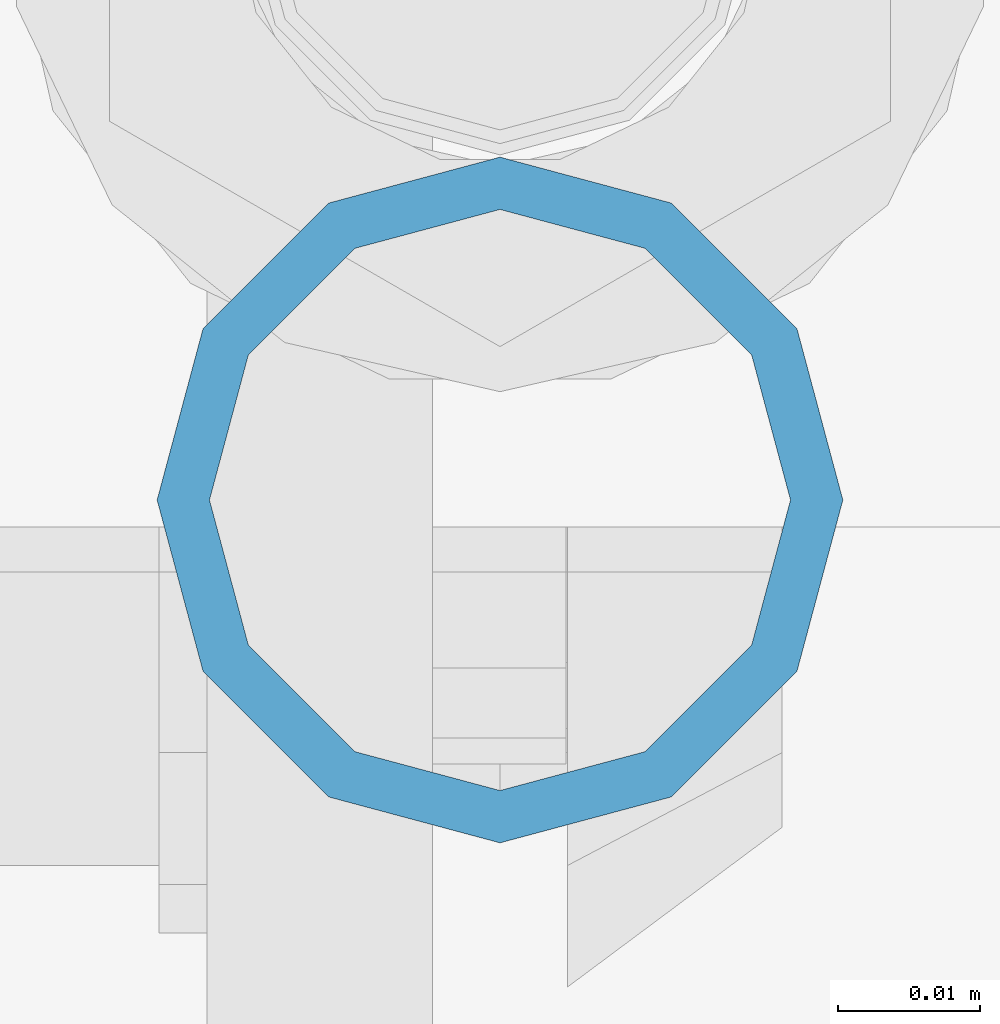
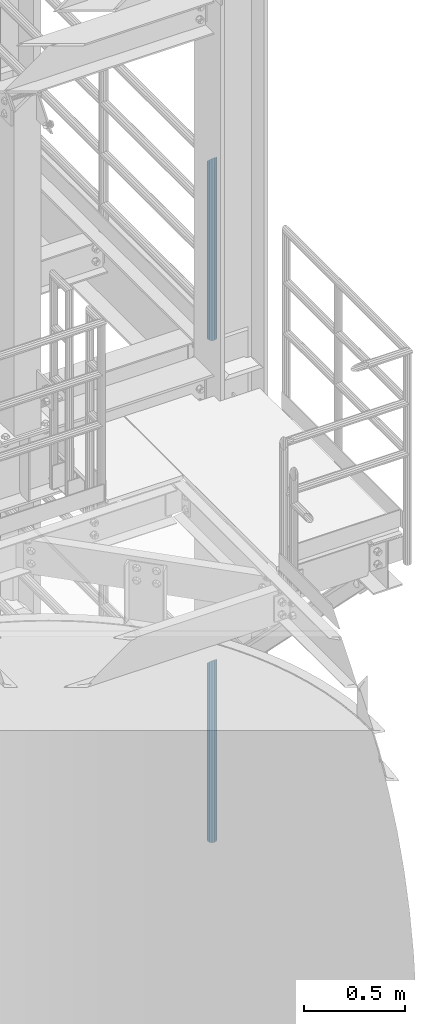
# One storey, part 657 of 1876: 2 columns, 2 elements without a shape of their own.
"""IFC2X3 building model written with IfcOpenShell, lengths in millimetres."""

from ifc_helpers import new_model, si_unit, frame, origin_with_axes, place, context, subcontext, project, spatial, faceted_brep, material, type_object, element, aggregate, save


model = new_model("IFC2X3")

# Units and contexts
model_context = context("Model", 3, precision=1e-05, world=origin_with_axes())
body_context = subcontext(model_context, "Body", "Model", "MODEL_VIEW")
ifc_project = project(units=[si_unit("LENGTHUNIT", "METRE", prefix="MILLI"), si_unit("AREAUNIT", "SQUARE_METRE"), si_unit("VOLUMEUNIT", "CUBIC_METRE"), si_unit("MASSUNIT", "GRAM", prefix="KILO"), si_unit("TIMEUNIT", "SECOND"), si_unit("PLANEANGLEUNIT", "RADIAN"), si_unit("SOLIDANGLEUNIT", "STERADIAN"), si_unit("THERMODYNAMICTEMPERATUREUNIT", "DEGREE_CELSIUS"), si_unit("LUMINOUSINTENSITYUNIT", "LUMEN")], contexts=[model_context])

# Site, building, storey
site_placement = place(None, origin_with_axes())
site = spatial("IfcSite", under=ifc_project, at=site_placement, CompositionType="ELEMENT")
building_placement = place(site_placement, origin_with_axes())
building = spatial("IfcBuilding", under=site, at=building_placement, Name="Undefined", CompositionType="ELEMENT")
storey_placement = place(building_placement, origin_with_axes())
storey = spatial("IfcBuildingStorey", under=building, at=storey_placement, Name="Undefined", CompositionType="ELEMENT", Elevation=0.0)

# Assembly, column
assembly_1_placement = place(storey_placement, origin_with_axes())
assembly_1 = element("IfcElementAssembly", 1, at=assembly_1_placement, inside=storey, Name="RAIL", AssemblyPlace="NOTDEFINED", PredefinedType="RIGID_FRAME")
ifc_material = material()
column_type = type_object("IfcColumnType", Name="PIPE1-1/2SCH40", PredefinedType="NOTDEFINED")
column_1_placement = place(assembly_1_placement, frame((7620.0, -6925.945, 8153.4), z_axis=(0.0, 1.0, 0.0), x_axis=(0.0, 0.0, 1.0)))
column_1 = element("IfcColumn", 2, at=column_1_placement, type_object=column_type, material=ifc_material, Name="POST", ObjectType="PIPE1-1/2SCH40", context=body_context, shape_type="Brep", body=[
    faceted_brep([(0.0, -20.4469999999999, 0.0), (0.0, -17.7076214311803, 10.2235000000001), (1066.1015, -17.7076214311803, 10.2235000000001), (1076.325, -20.4469999999999, 0.0), (0.0, -10.2235000000001, 17.7076214311801), (1058.61737856882, -10.2235000000001, 17.7076214311801), (-1.45519152283669e-11, 0.0, 20.4470000000001), (1055.878, 0.0, 20.4470000000001), (0.0, 10.2235000000001, 17.7076214311801), (1058.61737856882, 10.2235000000001, 17.7076214311801), (0.0, 17.7076214311803, 10.2235000000001), (1066.1015, 17.7076214311803, 10.2235000000001), (0.0, 20.4469999999999, 0.0), (1076.325, 20.4469999999999, 0.0), (0.0, 17.7076214311803, -10.2235000000001), (1086.5485, 17.7076214311803, -10.2235000000001), (0.0, 10.2235000000001, -17.7076214311801), (1094.03262143118, 10.2235000000001, -17.7076214311801), (-1.45519152283669e-11, 0.0, -20.4470000000001), (1096.772, 0.0, -20.4470000000001), (0.0, -10.2235000000001, -17.7076214311801), (1094.03262143118, -10.2235000000001, -17.7076214311801), (0.0, -17.7076214311803, -10.2235000000001), (1086.5485, -17.7076214311803, -10.2235000000001), (0.0, -24.1299999999992, 0.0), (0.0, -20.8971929933184, -12.0649999999996), (1088.39, -20.8971929933184, -12.0649999999996), (1076.325, -24.1300000000001, 0.0), (0.0, -12.0650000000001, -20.8971929933186), (1097.22219299332, -12.0650000000001, -20.8971929933186), (-1.45519152283669e-11, 0.0, -24.130000000001), (1100.455, 0.0, -24.1300000000001), (0.0, 12.0650000000001, -20.8971929933186), (1097.22219299332, 12.0650000000001, -20.8971929933186), (0.0, 20.8971929933184, -12.0649999999996), (1088.39, 20.8971929933184, -12.0649999999996), (0.0, 24.1299999999992, 0.0), (1076.325, 24.1300000000001, 0.0), (0.0, 20.8971929933184, 12.0649999999996), (1064.26, 20.8971929933184, 12.0649999999996), (0.0, 12.0650000000001, 20.8971929933186), (1055.42780700668, 12.0650000000001, 20.8971929933186), (-1.45519152283669e-11, 0.0, 24.130000000001), (1052.195, 0.0, 24.1300000000001), (0.0, -12.0650000000001, 20.8971929933186), (1055.42780700668, -12.0650000000001, 20.8971929933186), (0.0, -20.8971929933184, 12.0649999999996), (1064.26, -20.8971929933184, 12.0649999999996)], [[[0, 1, 2, 3]], [[1, 4, 5, 2]], [[4, 6, 7, 5]], [[6, 8, 9, 7]], [[8, 10, 11, 9]], [[10, 12, 13, 11]], [[12, 14, 15, 13]], [[14, 16, 17, 15]], [[16, 18, 19, 17]], [[18, 20, 21, 19]], [[20, 22, 23, 21]], [[22, 0, 3, 23]], [[24, 25, 26, 27]], [[25, 28, 29, 26]], [[28, 30, 31, 29]], [[30, 32, 33, 31]], [[32, 34, 35, 33]], [[34, 36, 37, 35]], [[36, 38, 39, 37]], [[38, 40, 41, 39]], [[40, 42, 43, 41]], [[42, 44, 45, 43]], [[44, 46, 47, 45]], [[46, 24, 27, 47]], [[29, 31, 33, 35, 37, 39, 41, 43, 45, 47, 27, 26], [5, 7, 9, 11, 13, 15, 17, 19, 21, 23, 3, 2]], [[46, 44, 42, 40, 38, 36, 34, 32, 30, 28, 25, 24], [22, 20, 18, 16, 14, 12, 10, 8, 6, 4, 1, 0]]]),
])
aggregate(assembly_1, [column_1])

assembly_2_placement = place(storey_placement, origin_with_axes())
assembly_2 = element("IfcElementAssembly", 3, at=assembly_2_placement, inside=storey, Name="RAIL", AssemblyPlace="NOTDEFINED", PredefinedType="RIGID_FRAME")
column_2_placement = place(assembly_2_placement, frame((7620.0, -6925.945, 5130.8), z_axis=(0.0, 1.0, 0.0), x_axis=(0.0, 0.0, 1.0)))
column_2 = element("IfcColumn", 4, at=column_2_placement, type_object=column_type, material=ifc_material, Name="POST", ObjectType="PIPE1-1/2SCH40", context=body_context, shape_type="Brep", body=[
    faceted_brep([(0.0, -20.4469999999999, 0.0), (0.0, -17.7076214311803, 10.2235000000001), (1066.1015, -17.7076214311803, 10.2235000000001), (1076.325, -20.4469999999999, 0.0), (0.0, -10.2235000000001, 17.7076214311801), (1058.61737856882, -10.2235000000001, 17.7076214311801), (-1.45519152283669e-11, 0.0, 20.4470000000001), (1055.878, 0.0, 20.4470000000001), (0.0, 10.2235000000001, 17.7076214311801), (1058.61737856882, 10.2235000000001, 17.7076214311801), (0.0, 17.7076214311803, 10.2235000000001), (1066.1015, 17.7076214311803, 10.2235000000001), (0.0, 20.4469999999999, 0.0), (1076.325, 20.4469999999999, 0.0), (0.0, 17.7076214311803, -10.2235000000001), (1086.5485, 17.7076214311803, -10.2235000000001), (0.0, 10.2235000000001, -17.7076214311801), (1094.03262143118, 10.2235000000001, -17.7076214311801), (-1.45519152283669e-11, 0.0, -20.4470000000001), (1096.772, 0.0, -20.4470000000001), (0.0, -10.2235000000001, -17.7076214311801), (1094.03262143118, -10.2235000000001, -17.7076214311801), (0.0, -17.7076214311803, -10.2235000000001), (1086.5485, -17.7076214311803, -10.2235000000001), (0.0, -24.1299999999992, 0.0), (0.0, -20.8971929933184, -12.0649999999996), (1088.39, -20.8971929933184, -12.0649999999996), (1076.325, -24.1300000000001, 0.0), (0.0, -12.0650000000001, -20.8971929933186), (1097.22219299332, -12.0650000000001, -20.8971929933186), (-1.45519152283669e-11, 0.0, -24.130000000001), (1100.455, 0.0, -24.1300000000001), (0.0, 12.0650000000001, -20.8971929933186), (1097.22219299332, 12.0650000000001, -20.8971929933186), (0.0, 20.8971929933184, -12.0649999999996), (1088.39, 20.8971929933184, -12.0649999999996), (0.0, 24.1299999999992, 0.0), (1076.325, 24.1300000000001, 0.0), (0.0, 20.8971929933184, 12.0649999999996), (1064.26, 20.8971929933184, 12.0649999999996), (0.0, 12.0650000000001, 20.8971929933186), (1055.42780700668, 12.0650000000001, 20.8971929933186), (-1.45519152283669e-11, 0.0, 24.130000000001), (1052.195, 0.0, 24.1300000000001), (0.0, -12.0650000000001, 20.8971929933186), (1055.42780700668, -12.0650000000001, 20.8971929933186), (0.0, -20.8971929933184, 12.0649999999996), (1064.26, -20.8971929933184, 12.0649999999996)], [[[0, 1, 2, 3]], [[1, 4, 5, 2]], [[4, 6, 7, 5]], [[6, 8, 9, 7]], [[8, 10, 11, 9]], [[10, 12, 13, 11]], [[12, 14, 15, 13]], [[14, 16, 17, 15]], [[16, 18, 19, 17]], [[18, 20, 21, 19]], [[20, 22, 23, 21]], [[22, 0, 3, 23]], [[24, 25, 26, 27]], [[25, 28, 29, 26]], [[28, 30, 31, 29]], [[30, 32, 33, 31]], [[32, 34, 35, 33]], [[34, 36, 37, 35]], [[36, 38, 39, 37]], [[38, 40, 41, 39]], [[40, 42, 43, 41]], [[42, 44, 45, 43]], [[44, 46, 47, 45]], [[46, 24, 27, 47]], [[29, 31, 33, 35, 37, 39, 41, 43, 45, 47, 27, 26], [5, 7, 9, 11, 13, 15, 17, 19, 21, 23, 3, 2]], [[46, 44, 42, 40, 38, 36, 34, 32, 30, 28, 25, 24], [22, 20, 18, 16, 14, 12, 10, 8, 6, 4, 1, 0]]]),
])
aggregate(assembly_2, [column_2])

save(model, "model.ifc")
